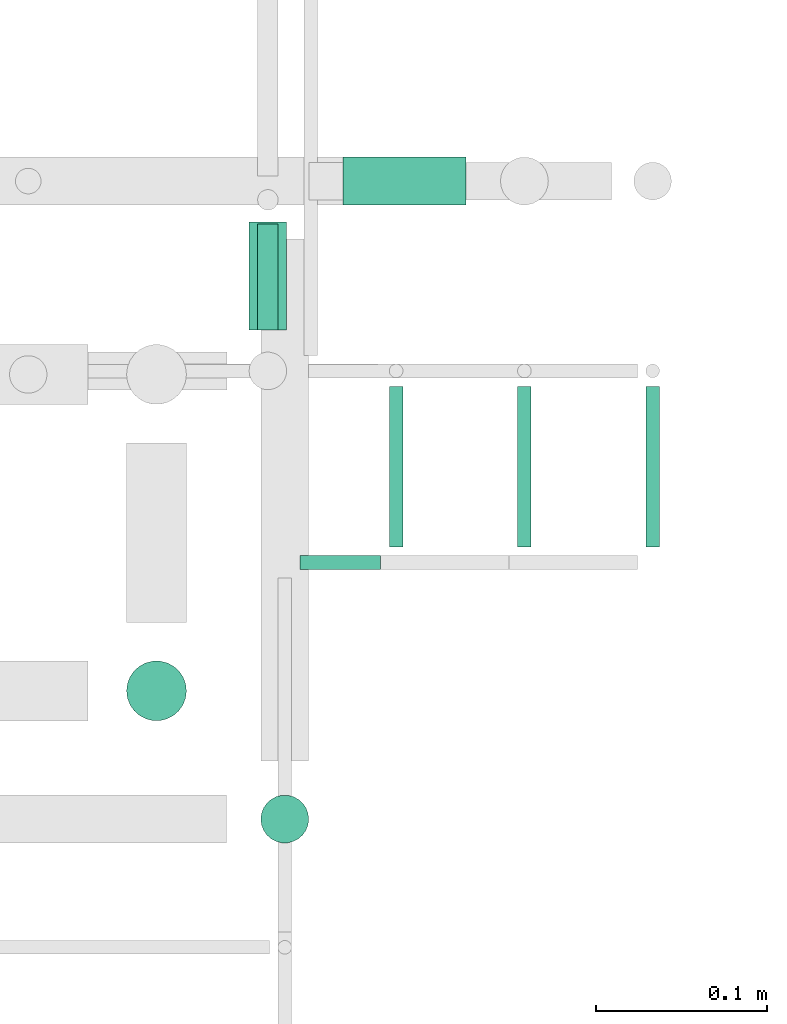
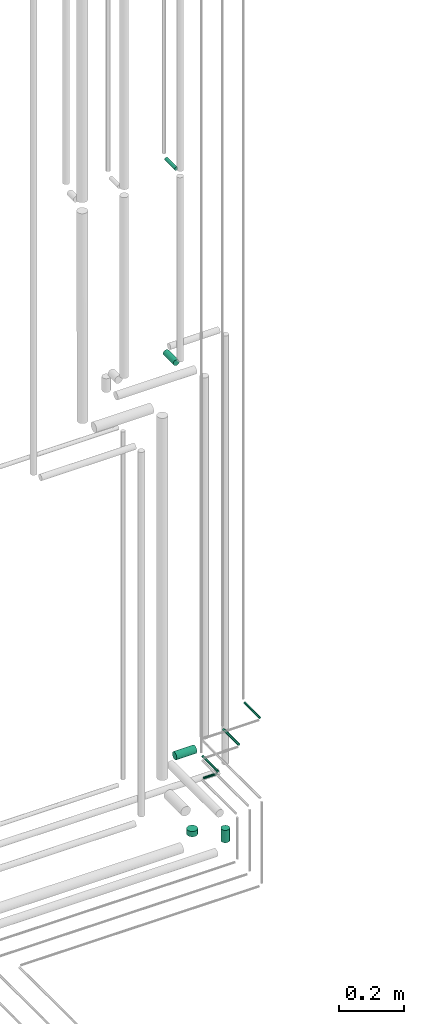
# One storey, part 313 of 331: 9 flow segments.
"""IFC2X3 building model written with IfcOpenShell, lengths in millimetres."""

from ifc_helpers import new_model, entity, si_unit, converted_unit, derived_unit, direction, frame, origin, origin_2d_with_axis, place, context, subcontext, project, spatial, circle, extrude, type_object, element, save


model = new_model("IFC2X3")

# Units and contexts
model_context = context("Model", 3, precision=0.01, world=origin(), true_north=direction((6.12303176911189e-17, 1.0)))
body_context = subcontext(model_context, "Body", "Model", "MODEL_VIEW")
ifc_project = project(units=[si_unit("LENGTHUNIT", "METRE", prefix="MILLI"), si_unit("AREAUNIT", "SQUARE_METRE"), si_unit("VOLUMEUNIT", "CUBIC_METRE"), converted_unit("PLANEANGLEUNIT", "DEGREE", entity("IfcRatioMeasure", 0.0174532925199433), si_unit("PLANEANGLEUNIT", "RADIAN"), dimensions=[0, 0, 0, 0, 0, 0, 0]), si_unit("MASSUNIT", "GRAM", prefix="KILO"), derived_unit("MASSDENSITYUNIT", [(si_unit("MASSUNIT", "GRAM", prefix="KILO"), 1), (si_unit("LENGTHUNIT", "METRE"), -3)]), derived_unit("MOMENTOFINERTIAUNIT", [(si_unit("LENGTHUNIT", "METRE"), 4)]), si_unit("TIMEUNIT", "SECOND"), si_unit("FREQUENCYUNIT", "HERTZ"), si_unit("THERMODYNAMICTEMPERATUREUNIT", "DEGREE_CELSIUS"), derived_unit("THERMALTRANSMITTANCEUNIT", [(si_unit("MASSUNIT", "GRAM", prefix="KILO"), 1), (si_unit("THERMODYNAMICTEMPERATUREUNIT", "KELVIN"), -1), (si_unit("TIMEUNIT", "SECOND"), -3)]), derived_unit("VOLUMETRICFLOWRATEUNIT", [(si_unit("LENGTHUNIT", "METRE"), 3), (si_unit("TIMEUNIT", "SECOND"), -1)]), derived_unit("MASSFLOWRATEUNIT", [(si_unit("MASSUNIT", "GRAM", prefix="KILO"), 1), (si_unit("TIMEUNIT", "SECOND"), -1)]), derived_unit("ROTATIONALFREQUENCYUNIT", [(si_unit("TIMEUNIT", "SECOND"), -1)]), si_unit("ELECTRICCURRENTUNIT", "AMPERE"), si_unit("ELECTRICVOLTAGEUNIT", "VOLT"), si_unit("POWERUNIT", "WATT"), si_unit("FORCEUNIT", "NEWTON", prefix="KILO"), si_unit("ILLUMINANCEUNIT", "LUX"), si_unit("LUMINOUSFLUXUNIT", "LUMEN"), si_unit("LUMINOUSINTENSITYUNIT", "CANDELA"), derived_unit("USERDEFINED", [(si_unit("MASSUNIT", "GRAM", prefix="KILO"), -1), (si_unit("LENGTHUNIT", "METRE"), -2), (si_unit("TIMEUNIT", "SECOND"), 3), (si_unit("LUMINOUSFLUXUNIT", "LUMEN"), 1)]), derived_unit("LINEARVELOCITYUNIT", [(si_unit("LENGTHUNIT", "METRE"), 1), (si_unit("TIMEUNIT", "SECOND"), -1)]), si_unit("PRESSUREUNIT", "PASCAL"), derived_unit("USERDEFINED", [(si_unit("LENGTHUNIT", "METRE"), -2), (si_unit("MASSUNIT", "GRAM", prefix="KILO"), 1), (si_unit("TIMEUNIT", "SECOND"), -2)]), derived_unit("LINEARFORCEUNIT", [(si_unit("MASSUNIT", "GRAM", prefix="KILO"), 1), (si_unit("LENGTHUNIT", "METRE"), 1), (si_unit("TIMEUNIT", "SECOND"), -2), (si_unit("LENGTHUNIT", "METRE"), -1)]), derived_unit("PLANARFORCEUNIT", [(si_unit("MASSUNIT", "GRAM", prefix="KILO"), 1), (si_unit("LENGTHUNIT", "METRE"), 1), (si_unit("TIMEUNIT", "SECOND"), -2), (si_unit("LENGTHUNIT", "METRE"), -2)])], contexts=[model_context])

# Site, building, storey
site_placement = place(None, frame((0.0, -0.00077364408347762, 0.0)))
site = spatial("IfcSite", under=ifc_project, at=site_placement, CompositionType="ELEMENT")
building_placement = place(site_placement, origin())
building = spatial("IfcBuilding", under=site, at=building_placement, CompositionType="ELEMENT")
storey_placement = place(building_placement, origin())
storey = spatial("IfcBuildingStorey", under=building, at=storey_placement, CompositionType="ELEMENT", Elevation=0.0)

# Flow segments
pipe_segment_type = type_object("IfcPipeSegmentType", PredefinedType="NOTDEFINED")
for number, where in (
    (1, (66929.5166110417, 8046.93026688114, 3019.40472776408)),
    (2, (66854.5166110417, 8046.93026688114, 2944.40472776408)),
):
    element("IfcFlowSegment", number, at=place(building_placement, frame(where)), inside=storey, type_object=pipe_segment_type, context=body_context, shape_type="SweptSolid", body=[
        extrude(circle(Radius=4.0, at=origin_2d_with_axis()), frame((5.59527223591499, 0.0, 5.59527223591607), z_axis=(0.0, 1.0, 0.0), x_axis=(1.0, 0.0, 0.0)), (0.0, 0.0, 1.0), 94.0703755139012),
    ])
flow_segment_1_placement = place(building_placement, frame((66728.9973266601, 8032.33499464522, 2869.40472776408)))
element("IfcFlowSegment", 3, at=flow_segment_1_placement, inside=storey, type_object=pipe_segment_type, context=body_context, shape_type="SweptSolid", body=[
    extrude(circle(Radius=4.0, at=origin_2d_with_axis()), frame((0.0, 5.59527223591607, 5.59527223591607), z_axis=(1.0, 0.0, 0.0), x_axis=(0.0, -1.0, 0.0)), (0.0, 0.0, 1.0), 47.1145566175184),
])
flow_segment_2_placement = place(building_placement, frame((66779.5166110417, 8046.93026688114, 2869.40472776408)))
element("IfcFlowSegment", 4, at=flow_segment_2_placement, inside=storey, type_object=pipe_segment_type, context=body_context, shape_type="SweptSolid", body=[
    extrude(circle(Radius=4.0, at=origin_2d_with_axis()), frame((5.59527223591499, 0.0, 5.59527223591607), z_axis=(0.0, 1.0, 0.0), x_axis=(1.0, 0.0, 0.0)), (0.0, 0.0, 1.0), 94.0703755139109),
])
flow_segment_3_placement = place(building_placement, frame((66702.5166110417, 8174.00064239506, 5092.40472776411)))
element("IfcFlowSegment", 5, at=flow_segment_3_placement, inside=storey, type_object=pipe_segment_type, context=body_context, shape_type="SweptSolid", body=[
    extrude(circle(Radius=6.0, at=origin_2d_with_axis()), frame((7.59527223591454, 0.0, 7.59527223591562), z_axis=(0.0, 1.0, 0.0), x_axis=(1.0, 0.0, 0.0)), (0.0, 0.0, 1.0), 61.9999999999967),
])
flow_segment_4_placement = place(building_placement, frame((66704.4020544242, 7872.33499464522, 2734.0)))
element("IfcFlowSegment", 6, at=flow_segment_4_placement, inside=storey, type_object=pipe_segment_type, context=body_context, shape_type="SweptSolid", body=[
    extrude(circle(Radius=14.0, at=origin_2d_with_axis()), frame((15.5952722359127, 15.595272235916, 0.0)), (0.0, 0.0, 1.0), 47.0000000000137),
])
flow_segment_5_placement = place(storey_placement, frame((66753.9973266601, 8245.40537015913, 2799.40472776408)))
element("IfcFlowSegment", 7, at=flow_segment_5_placement, inside=storey, type_object=pipe_segment_type, context=body_context, shape_type="SweptSolid", body=[
    extrude(circle(Radius=14.0, at=origin_2d_with_axis()), frame((0.0, 15.5952722359203, 15.595272235916), z_axis=(1.0, 0.0, 0.0), x_axis=(0.0, -1.0, 0.0)), (0.0, 0.0, 1.0), 72.1145566175387),
])
flow_segment_6_placement = place(building_placement, frame((66625.9020544242, 7943.83499464522, 2740.0)))
element("IfcFlowSegment", 8, at=flow_segment_6_placement, inside=storey, type_object=pipe_segment_type, context=body_context, shape_type="SweptSolid", body=[
    extrude(circle(Radius=17.5, at=origin_2d_with_axis()), frame((19.0952722359119, 19.0952722359163, 0.0)), (0.0, 0.0, 1.0), 20.0000000000566),
])
flow_segment_7_placement = place(building_placement, frame((66697.5166110417, 8174.00064239509, 4355.20075026172)))
element("IfcFlowSegment", 9, at=flow_segment_7_placement, inside=storey, type_object=pipe_segment_type, context=body_context, shape_type="SweptSolid", body=[
    extrude(circle(Radius=11.0, at=origin_2d_with_axis()), frame((12.5952722359047, 0.0, 12.5952722359161), z_axis=(0.0, 1.0, 0.0), x_axis=(-1.0, 0.0, 0.0)), (0.0, 0.0, 1.0), 62.9999999999629),
])

save(model, "model.ifc")
